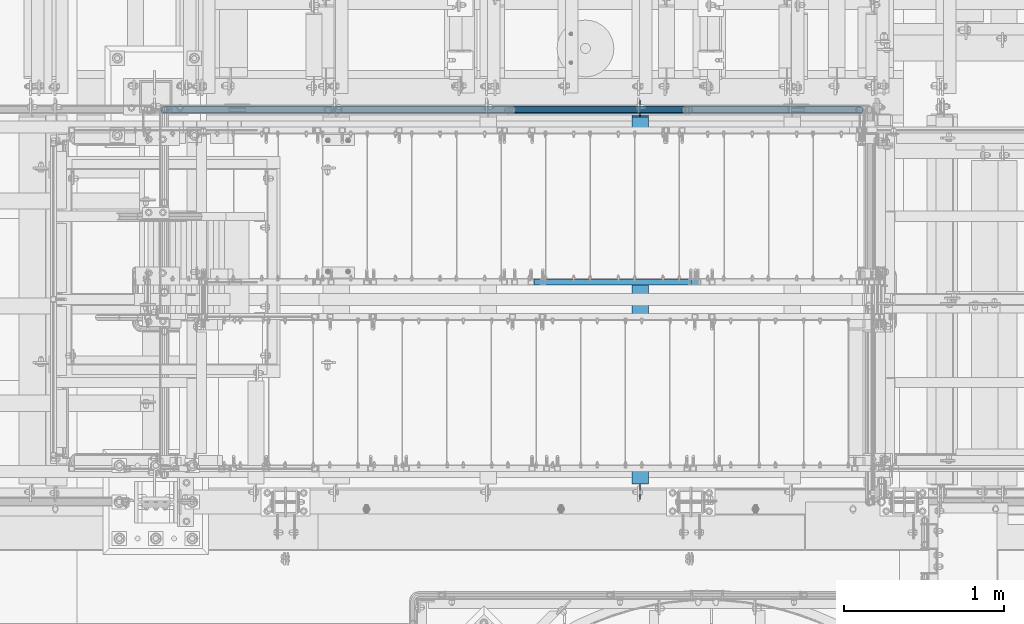
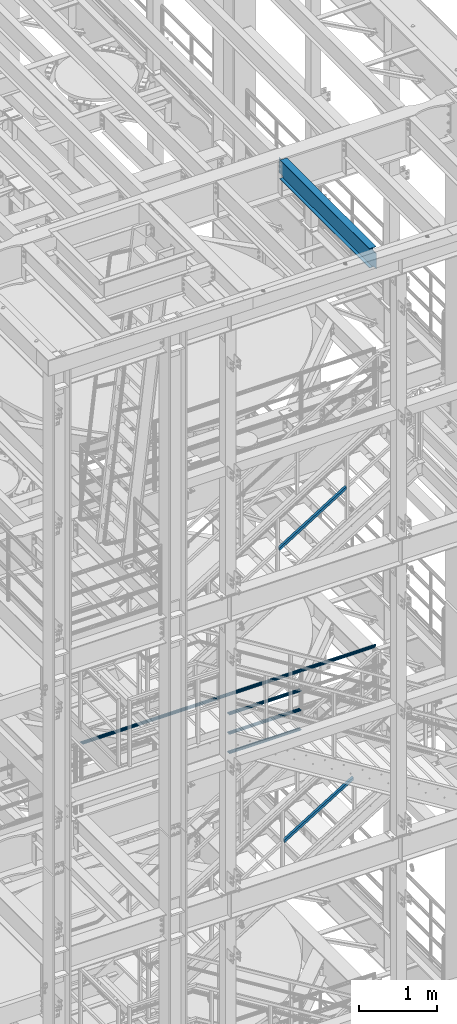
# One storey, part 976 of 1876: 5 beams, 2 members, 4 elements without a shape of their own.
"""IFC2X3 building model written with IfcOpenShell, lengths in millimetres."""

from ifc_helpers import new_model, si_unit, frame, origin_with_axes, place, context, subcontext, project, spatial, faceted_brep, material, type_object, element, aggregate, save


model = new_model("IFC2X3")

# Units and contexts
model_context = context("Model", 3, precision=1e-05, world=origin_with_axes())
body_context = subcontext(model_context, "Body", "Model", "MODEL_VIEW")
ifc_project = project(units=[si_unit("LENGTHUNIT", "METRE", prefix="MILLI"), si_unit("AREAUNIT", "SQUARE_METRE"), si_unit("VOLUMEUNIT", "CUBIC_METRE"), si_unit("MASSUNIT", "GRAM", prefix="KILO"), si_unit("TIMEUNIT", "SECOND"), si_unit("PLANEANGLEUNIT", "RADIAN"), si_unit("SOLIDANGLEUNIT", "STERADIAN"), si_unit("THERMODYNAMICTEMPERATUREUNIT", "DEGREE_CELSIUS"), si_unit("LUMINOUSINTENSITYUNIT", "LUMEN")], contexts=[model_context])

# Site, building, storey
site_placement = place(None, origin_with_axes())
site = spatial("IfcSite", under=ifc_project, at=site_placement, CompositionType="ELEMENT")
building_placement = place(site_placement, origin_with_axes())
building = spatial("IfcBuilding", under=site, at=building_placement, Name="Undefined", CompositionType="ELEMENT")
storey_placement = place(building_placement, origin_with_axes())
storey = spatial("IfcBuildingStorey", under=building, at=storey_placement, Name="Undefined", CompositionType="ELEMENT", Elevation=0.0)

# Assembly, beams
assembly_1_placement = place(storey_placement, origin_with_axes())
assembly_1 = element("IfcElementAssembly", 1, at=assembly_1_placement, inside=storey, Name="RAIL", AssemblyPlace="NOTDEFINED", PredefinedType="RIGID_FRAME")
ifc_material_1 = material()
beam_type_1 = type_object("IfcBeamType", Name="PIPE1-1/2SCH40", PredefinedType="NOTDEFINED")
beam_1_placement = place(assembly_1_placement, frame((5048.24999996466, -4654.55000114566, 13471.525), z_axis=(0.0, 0.0, 1.0), x_axis=(-1.0, 0.0, 0.0)))
beam_1 = element("IfcBeam", 2, at=beam_1_placement, type_object=beam_type_1, material=ifc_material_1, Name="RAIL", ObjectType="PIPE1-1/2SCH40", context=body_context, shape_type="Brep", body=[
    faceted_brep([(1068.12780699489, -12.0649999999996, 20.8971929933177), (1068.12780699489, -12.064999999986, 15.8661214311942), (1067.63437855703, -10.2235000000001, 17.7076214311801), (1064.89499998821, 0.0, 20.4470000000001), (1064.89499998821, 0.0, 24.1299999999992), (1067.63437855703, 10.2235000000001, 17.7076214311801), (1068.12780699489, 12.0650000000132, 15.8661214311669), (1068.12780699489, 12.0649999999996, 20.8971929933177), (1089.02499998822, 24.1300000000001, 0.0), (1076.95999998821, 20.8971929933186, 12.0650000000005), (1076.95999998821, 20.8971929933186, -12.0650000000005), (1073.77042842606, 17.7076214311801, 10.2235000000001), (1076.50980699488, 20.4470000000001, 0.0), (1073.77042842606, 17.7076214311801, -10.2235000000001), (1068.12780699489, 12.0650000000132, -15.8661214311669), (1068.12780699489, 12.0649999999996, -20.8971929933177), (1067.63437855703, 10.2235000000001, -17.7076214311801), (1064.89499998821, 0.0, -20.4470000000001), (1064.89499998821, 0.0, -24.1299999999992), (1068.12780699489, -12.064999999986, -15.8661214311942), (1068.12780699489, -12.0649999999996, -20.8971929933177), (1067.63437855703, -10.2235000000001, -17.7076214311801), (1089.02499998821, -24.1299999999865, 0.0), (1076.95999998821, -20.8971929933186, -12.0650000000005), (1076.95999998821, -20.8971929933186, 12.0650000000005), (1073.77042842609, -17.7076214311801, -10.2235000000001), (1076.50980699491, -20.4470000000001, 0.0), (1073.77042842609, -17.7076214311801, 10.2235000000001), (12.0650000000064, -20.8971929933177, -12.0649999999987), (20.8971929933249, -12.0650000000005, -20.8971929933177), (0.0, 24.1299999999992, 0.0), (12.0650000000064, 20.8971929933177, -12.0649999999987), (12.0650000000064, 20.8971929933177, 12.0649999999987), (20.8971929933249, 12.0650000000005, 20.8971929933177), (24.1300000000064, 0.0, 24.130000000001), (20.8971929933249, 12.0650000000005, -20.8971929933177), (24.1300000000063, 0.0, -24.130000000001), (24.1300000000063, 0.0, -20.4470000000001), (20.8971929933249, -12.0650000000005, -15.8661214311796), (21.3906214311868, -10.2235000000001, -17.7076214311819), (21.3906214311868, 10.2235000000001, -17.7076214311819), (20.8971929933249, 12.0650000000005, -15.8661214311796), (15.2545715621445, 17.7076214311801, -10.2235000000001), (12.5151929933249, 20.4470000000001, 0.0), (15.2545715621445, 17.7076214311801, 10.2235000000001), (20.8971929933249, 12.0650000000005, 15.8661214311796), (21.3906214311868, 10.2235000000001, 17.7076214311819), (24.1300000000064, 0.0, 20.4470000000001), (21.3906214311868, -10.2235000000001, 17.7076214311819), (20.8971929933249, -12.0650000000005, 15.8661214311796), (20.8971929933249, -12.0650000000005, 20.8971929933177), (12.0650000000064, -20.8971929933177, 12.0649999999987), (0.0, -24.1299999999992, 0.0), (15.2545715621445, -17.7076214311801, 10.2235000000001), (12.5151929933249, -20.4470000000001, 0.0), (15.2545715621445, -17.7076214311801, -10.2235000000001)], [[[0, 1, 2, 3, 4]], [[4, 3, 5, 6, 7]], [[8, 9, 10]], [[7, 6, 11, 12, 13, 14, 15, 10, 9]], [[16, 17, 18, 15, 14]], [[19, 20, 18, 17, 21]], [[22, 23, 24]], [[24, 23, 20, 19, 25, 26, 27, 1, 0]], [[28, 29, 20, 23]], [[30, 31, 32]], [[33, 34, 4, 7]], [[32, 33, 7, 9]], [[30, 32, 9, 8]], [[31, 30, 8, 10]], [[35, 31, 10, 15]], [[36, 35, 15, 18]], [[29, 36, 18, 20]], [[37, 36, 29, 38, 39]], [[40, 41, 35, 36, 37]], [[32, 31, 35, 41, 42, 43, 44, 45, 33]], [[33, 45, 46, 47, 34]], [[34, 47, 48, 49, 50]], [[34, 50, 0, 4]], [[50, 51, 24, 0]], [[51, 52, 22, 24]], [[52, 28, 23, 22]], [[51, 28, 52]], [[50, 49, 53, 54, 55, 38, 29, 28, 51]], [[55, 54, 26, 25]], [[21, 39, 38, 55, 25, 19]], [[37, 39, 21, 17]], [[40, 37, 17, 16]], [[42, 41, 40, 16, 14, 13]], [[43, 42, 13, 12]], [[44, 43, 12, 11]], [[5, 46, 45, 44, 11, 6]], [[47, 46, 5, 3]], [[48, 47, 3, 2]], [[53, 49, 48, 2, 1, 27]], [[54, 53, 27, 26]]]),
])
beam_2_placement = place(assembly_1_placement, frame((3959.22499997644, -4654.55000114568, 13776.325), z_axis=(0.0, 0.0, -1.0), x_axis=(1.0, 0.0, 0.0)))
beam_2 = element("IfcBeam", 3, at=beam_2_placement, type_object=beam_type_1, material=ifc_material_1, Name="RAIL", ObjectType="PIPE1-1/2SCH40", context=body_context, shape_type="Brep", body=[
    faceted_brep([(0.0, 24.1299999999992, 0.0), (12.0650000000064, 20.8971929933177, -12.0649999999987), (12.0650000000064, 20.8971929933177, 12.0649999999987), (12.0650000000064, -20.8971929933177, 12.0649999999987), (12.0650000000064, -20.8971929933177, -12.0649999999987), (0.0, -24.1299999999992, 0.0), (20.8971929933249, -12.0650000000005, 20.8971929933177), (20.8971929933249, -12.0650000000005, 15.8661214311796), (15.2545715621445, -17.7076214311801, 10.2235000000001), (12.5151929933249, -20.4470000000001, 0.0), (15.2545715621445, -17.7076214311801, -10.2235000000001), (20.8971929933249, -12.0650000000005, -15.8661214311796), (20.8971929933249, -12.0650000000005, -20.8971929933177), (24.1300000000063, 0.0, -20.4470000000001), (24.1300000000063, 0.0, -24.130000000001), (21.3906214311868, -10.2235000000001, -17.7076214311819), (21.3906214311868, 10.2235000000001, -17.7076214311819), (20.8971929933249, 12.0650000000005, -15.8661214311796), (20.8971929933249, 12.0650000000005, -20.8971929933177), (15.2545715621445, 17.7076214311801, -10.2235000000001), (12.5151929933249, 20.4470000000001, 0.0), (15.2545715621445, 17.7076214311801, 10.2235000000001), (20.8971929933249, 12.0650000000005, 15.8661214311796), (20.8971929933249, 12.0650000000005, 20.8971929933177), (21.3906214311868, 10.2235000000001, 17.7076214311819), (24.1300000000064, 0.0, 20.4470000000001), (24.1300000000064, 0.0, 24.130000000001), (21.3906214311868, -10.2235000000001, 17.7076214311819), (1089.02499998822, 24.1300000000001, 0.0), (1076.95999998821, 20.8971929933186, -12.0650000000005), (1068.12780699489, 12.0649999999996, -20.8971929933177), (1089.02499998821, -24.1299999999865, 0.0), (1076.95999998821, -20.8971929933186, -12.0650000000005), (1076.95999998821, -20.8971929933186, 12.0650000000005), (1068.12780699489, -12.0649999999996, 20.8971929933177), (1068.12780699489, -12.0649999999996, -20.8971929933177), (1064.89499998821, 0.0, -24.1299999999992), (1067.63437855703, 10.2235000000001, -17.7076214311801), (1064.89499998821, 0.0, -20.4470000000001), (1068.12780699489, 12.0650000000132, -15.8661214311669), (1068.12780699489, -12.064999999986, -15.8661214311942), (1067.63437855703, -10.2235000000001, -17.7076214311801), (1073.77042842609, -17.7076214311801, -10.2235000000001), (1076.50980699491, -20.4470000000001, 0.0), (1073.77042842609, -17.7076214311801, 10.2235000000001), (1068.12780699489, -12.064999999986, 15.8661214311942), (1067.63437855703, -10.2235000000001, 17.7076214311801), (1064.89499998821, 0.0, 20.4470000000001), (1064.89499998821, 0.0, 24.1299999999992), (1068.12780699489, 12.0649999999996, 20.8971929933177), (1076.95999998821, 20.8971929933186, 12.0650000000005), (1068.12780699489, 12.0650000000132, 15.8661214311669), (1073.77042842606, 17.7076214311801, 10.2235000000001), (1076.50980699488, 20.4470000000001, 0.0), (1073.77042842606, 17.7076214311801, -10.2235000000001), (1067.63437855703, 10.2235000000001, 17.7076214311801)], [[[0, 1, 2]], [[3, 4, 5]], [[6, 7, 8, 9, 10, 11, 12, 4, 3]], [[13, 14, 12, 11, 15]], [[16, 17, 18, 14, 13]], [[2, 1, 18, 17, 19, 20, 21, 22, 23]], [[23, 22, 24, 25, 26]], [[26, 25, 27, 7, 6]], [[1, 0, 28, 29]], [[18, 1, 29, 30]], [[31, 32, 33]], [[6, 3, 33, 34]], [[3, 5, 31, 33]], [[5, 4, 32, 31]], [[4, 12, 35, 32]], [[12, 14, 36, 35]], [[14, 18, 30, 36]], [[37, 38, 36, 30, 39]], [[40, 35, 36, 38, 41]], [[33, 32, 35, 40, 42, 43, 44, 45, 34]], [[34, 45, 46, 47, 48]], [[26, 6, 34, 48]], [[2, 23, 49, 50]], [[23, 26, 48, 49]], [[0, 2, 50, 28]], [[28, 50, 29]], [[49, 51, 52, 53, 54, 39, 30, 29, 50]], [[48, 47, 55, 51, 49]], [[25, 24, 55, 47]], [[55, 24, 22, 21, 52, 51]], [[21, 20, 53, 52]], [[20, 19, 54, 53]], [[19, 17, 16, 37, 39, 54]], [[16, 13, 38, 37]], [[13, 15, 41, 38]], [[41, 15, 11, 10, 42, 40]], [[10, 9, 43, 42]], [[9, 8, 44, 43]], [[8, 7, 27, 46, 45, 44]], [[27, 25, 47, 46]]]),
])
beam_3_placement = place(assembly_1_placement, frame((3959.22499997644, -4654.55000114568, 14081.125), z_axis=(0.0, 0.0, -1.0), x_axis=(1.0, 0.0, 0.0)))
beam_3 = element("IfcBeam", 4, at=beam_3_placement, type_object=beam_type_1, material=ifc_material_1, Name="RAIL", ObjectType="PIPE1-1/2SCH40", context=body_context, shape_type="Brep", body=[
    faceted_brep([(0.0, 24.1299999999992, 0.0), (12.0650000000064, 20.8971929933177, -12.0649999999987), (12.0650000000064, 20.8971929933177, 12.0649999999987), (12.0650000000064, -20.8971929933177, 12.0649999999987), (12.0650000000064, -20.8971929933177, -12.0649999999987), (0.0, -24.1299999999992, 0.0), (20.8971929933249, -12.0650000000005, 20.8971929933177), (20.8971929933249, -12.0650000000005, 15.8661214311796), (15.2545715621445, -17.7076214311801, 10.2235000000001), (12.5151929933249, -20.4470000000001, 0.0), (15.2545715621445, -17.7076214311801, -10.2235000000001), (20.8971929933249, -12.0650000000005, -15.8661214311796), (20.8971929933249, -12.0650000000005, -20.8971929933177), (24.1300000000063, 0.0, -20.4470000000001), (24.1300000000063, 0.0, -24.130000000001), (21.3906214311868, -10.2235000000001, -17.7076214311819), (21.3906214311868, 10.2235000000001, -17.7076214311819), (20.8971929933249, 12.0650000000005, -15.8661214311796), (20.8971929933249, 12.0650000000005, -20.8971929933177), (15.2545715621445, 17.7076214311801, -10.2235000000001), (12.5151929933249, 20.4470000000001, 0.0), (15.2545715621445, 17.7076214311801, 10.2235000000001), (20.8971929933249, 12.0650000000005, 15.8661214311796), (20.8971929933249, 12.0650000000005, 20.8971929933177), (21.3906214311868, 10.2235000000001, 17.7076214311819), (24.1300000000064, 0.0, 20.4470000000001), (24.1300000000064, 0.0, 24.130000000001), (21.3906214311868, -10.2235000000001, 17.7076214311819), (1089.02499998822, 24.1300000000001, 0.0), (1076.95999998821, 20.8971929933186, -12.0650000000005), (1068.12780699489, 12.0649999999996, -20.8971929933177), (1089.02499998821, -24.1299999999865, 0.0), (1076.95999998821, -20.8971929933186, -12.0650000000005), (1076.95999998821, -20.8971929933186, 12.0650000000005), (1068.12780699489, -12.0649999999996, 20.8971929933177), (1068.12780699489, -12.0649999999996, -20.8971929933177), (1064.89499998821, 0.0, -24.1299999999992), (1067.63437855703, 10.2235000000001, -17.7076214311801), (1064.89499998821, 0.0, -20.4470000000001), (1068.12780699489, 12.0650000000132, -15.8661214311669), (1068.12780699489, -12.064999999986, -15.8661214311942), (1067.63437855703, -10.2235000000001, -17.7076214311801), (1073.77042842609, -17.7076214311801, -10.2235000000001), (1076.50980699491, -20.4470000000001, 0.0), (1073.77042842609, -17.7076214311801, 10.2235000000001), (1068.12780699489, -12.064999999986, 15.8661214311942), (1067.63437855703, -10.2235000000001, 17.7076214311801), (1064.89499998821, 0.0, 20.4470000000001), (1064.89499998821, 0.0, 24.1299999999992), (1068.12780699489, 12.0649999999996, 20.8971929933177), (1076.95999998821, 20.8971929933186, 12.0650000000005), (1068.12780699489, 12.0650000000132, 15.8661214311669), (1073.77042842606, 17.7076214311801, 10.2235000000001), (1076.50980699488, 20.4470000000001, 0.0), (1073.77042842606, 17.7076214311801, -10.2235000000001), (1067.63437855703, 10.2235000000001, 17.7076214311801)], [[[0, 1, 2]], [[3, 4, 5]], [[6, 7, 8, 9, 10, 11, 12, 4, 3]], [[13, 14, 12, 11, 15]], [[16, 17, 18, 14, 13]], [[2, 1, 18, 17, 19, 20, 21, 22, 23]], [[23, 22, 24, 25, 26]], [[26, 25, 27, 7, 6]], [[1, 0, 28, 29]], [[18, 1, 29, 30]], [[31, 32, 33]], [[6, 3, 33, 34]], [[3, 5, 31, 33]], [[5, 4, 32, 31]], [[4, 12, 35, 32]], [[12, 14, 36, 35]], [[14, 18, 30, 36]], [[37, 38, 36, 30, 39]], [[40, 35, 36, 38, 41]], [[33, 32, 35, 40, 42, 43, 44, 45, 34]], [[34, 45, 46, 47, 48]], [[26, 6, 34, 48]], [[2, 23, 49, 50]], [[23, 26, 48, 49]], [[0, 2, 50, 28]], [[28, 50, 29]], [[49, 51, 52, 53, 54, 39, 30, 29, 50]], [[48, 47, 55, 51, 49]], [[25, 24, 55, 47]], [[55, 24, 22, 21, 52, 51]], [[21, 20, 53, 52]], [[20, 19, 54, 53]], [[19, 17, 16, 37, 39, 54]], [[16, 13, 38, 37]], [[13, 15, 41, 38]], [[41, 15, 11, 10, 42, 40]], [[10, 9, 43, 42]], [[9, 8, 44, 43]], [[8, 7, 27, 46, 45, 44]], [[27, 25, 47, 46]]]),
])
beam_4_placement = place(assembly_1_placement, frame((1757.04499999999, -4654.55000114569, 14385.925), z_axis=(0.0, 0.0, -1.0), x_axis=(1.0, 0.0, 0.0)))
beam_4 = element("IfcBeam", 5, at=beam_4_placement, type_object=beam_type_1, material=ifc_material_1, Name="RAIL", ObjectType="PIPE1-1/2SCH40", context=body_context, shape_type="Brep", body=[
    faceted_brep([(24.1300000000001, -20.4469999999999, 0.0), (34.3535000000002, -17.7076214311803, 10.2235000000001), (4370.00649995292, -17.7076214311801, 10.2235000000001), (4380.22999995292, -20.4470000000001, 0.0), (41.8376214311802, -10.2235000000001, 17.7076214311819), (4362.52237852174, -10.2235000000001, 17.7076214311801), (44.5770000000002, 0.0, 20.4470000000001), (4359.78299995292, 0.0, 20.4470000000001), (41.8376214311802, 10.2235000000001, 17.7076214311819), (4362.52237852174, 10.2235000000001, 17.7076214311801), (34.3535000000002, 17.7076214311803, 10.2235000000001), (4370.00649995292, 17.7076214311801, 10.2235000000001), (24.1300000000001, 20.4469999999999, 0.0), (4380.22999995292, 20.4470000000001, 0.0), (13.9065000000001, 17.7076214311803, -10.2235000000001), (4390.45349995292, 17.7076214311801, -10.2235000000001), (6.42237856882002, 10.2235000000001, -17.7076214311819), (4397.9376213841, 10.2235000000001, -17.7076214311801), (3.68299999999999, 0.0, -20.4470000000001), (4400.67699995292, 0.0, -20.4470000000001), (6.42237856882002, -10.2235000000001, -17.7076214311819), (4397.9376213841, -10.2235000000001, -17.7076214311801), (13.9065000000001, -17.7076214311803, -10.2235000000001), (4390.45349995292, -17.7076214311801, -10.2235000000001), (24.1299999999854, -24.1299999999992, 0.0), (12.0650000000064, -20.8971929933177, -12.0649999999987), (4392.29499995292, -20.8971929933186, -12.0650000000005), (4380.22999995292, -24.1300000000001, 0.0), (3.23280700668147, -12.0650000000001, -20.8971929933177), (4401.12719294624, -12.0649999999996, -20.8971929933177), (-1.45519152283669e-11, 0.0, -24.130000000001), (4404.35999995292, 0.0, -24.1299999999992), (3.23280700668147, 12.0650000000001, -20.8971929933177), (4401.12719294624, 12.0649999999996, -20.8971929933177), (12.0650000000064, 20.8971929933177, -12.0649999999987), (4392.29499995292, 20.8971929933186, -12.0650000000005), (24.1300000000047, 24.1299999999992, 0.0), (4380.22999995292, 24.1300000000001, 0.0), (36.1949999999997, 20.8971929933184, 12.0649999999987), (4368.16499995292, 20.8971929933186, 12.0650000000005), (45.0271929933187, 12.0650000000001, 20.8971929933177), (4359.3328069596, 12.0649999999996, 20.8971929933177), (48.2600000000002, 0.0, 24.130000000001), (4356.09999995292, 0.0, 24.1299999999992), (45.0271929933187, -12.0650000000001, 20.8971929933177), (4359.3328069596, -12.0649999999996, 20.8971929933177), (36.1949999999997, -20.8971929933184, 12.0649999999987), (4368.16499995292, -20.8971929933186, 12.0650000000005)], [[[0, 1, 2, 3]], [[1, 4, 5, 2]], [[4, 6, 7, 5]], [[6, 8, 9, 7]], [[8, 10, 11, 9]], [[10, 12, 13, 11]], [[12, 14, 15, 13]], [[14, 16, 17, 15]], [[16, 18, 19, 17]], [[18, 20, 21, 19]], [[20, 22, 23, 21]], [[22, 0, 3, 23]], [[24, 25, 26, 27]], [[25, 28, 29, 26]], [[28, 30, 31, 29]], [[30, 32, 33, 31]], [[32, 34, 35, 33]], [[34, 36, 37, 35]], [[36, 38, 39, 37]], [[38, 40, 41, 39]], [[40, 42, 43, 41]], [[42, 44, 45, 43]], [[44, 46, 47, 45]], [[46, 24, 27, 47]], [[29, 31, 33, 35, 37, 39, 41, 43, 45, 47, 27, 26], [5, 7, 9, 11, 13, 15, 17, 19, 21, 23, 3, 2]], [[46, 44, 42, 40, 38, 36, 34, 32, 30, 28, 25, 24], [22, 20, 18, 16, 14, 12, 10, 8, 6, 4, 1, 0]]]),
])
aggregate(assembly_1, [beam_1, beam_2, beam_3, beam_4])

# Assembly, beam
assembly_2_placement = place(storey_placement, origin_with_axes())
assembly_2 = element("IfcElementAssembly", 6, at=assembly_2_placement, inside=storey, Name="BEAM", AssemblyPlace="NOTDEFINED", PredefinedType="RIGID_FRAME")
ifc_material_2 = material(Name="STEEL/A992")
beam_type_2 = type_object("IfcBeamType", Name="W12X16", PredefinedType="NOTDEFINED")
beam_5_placement = place(assembly_2_placement, frame((4762.5, -7112.0, 22402.8), z_axis=(0.0, 0.0, 1.0), x_axis=(0.0, 1.0, 0.0)))
beam_5 = element("IfcBeam", 7, at=beam_5_placement, type_object=beam_type_2, material=ifc_material_2, Name="BEAM", ObjectType="W12X16", context=body_context, shape_type="Brep", body=[
    faceted_brep([(17.4625000000005, -3.17500000000018, -126.999999999999), (17.4625000000005, 3.17500000000018, -126.999999999999), (100.012500190734, 3.17500000000018, -126.999999999999), (100.012500190734, -3.17500000000018, -126.999999999999), (104.87257970878, 3.17500000000018, -127.966729922587), (104.87257970878, -3.17500000000018, -127.966729922587), (108.992756176934, 3.17500000000018, -130.719743823065), (108.992756176934, -3.17500000000018, -130.719743823065), (111.745770077412, 3.17500000000018, -134.839920291219), (111.745770077412, -3.17500000000018, -134.839920291219), (112.7125, -3.17500000000018, -139.699999809264), (112.7125, 3.17500000000018, -139.699999809264), (112.712500000001, 3.17500000000018, -146.049999999999), (112.7125, 50.8000000000002, -146.05), (112.7125, 50.8000000000002, -152.4), (112.7125, -50.8000000000002, -152.4), (112.7125, -50.8000000000002, -146.05), (112.712500000001, -3.17500000000018, -146.049999999999), (2412.20625, 50.8000000000002, 146.049999999999), (2412.20625, 3.17500000000018, 146.049999999999), (112.712500000001, 3.17500000000018, 146.05), (112.712500000001, 50.8000000000002, 146.049999999999), (100.012500190735, -3.17500000000018, 114.299999999996), (100.012500190735, 3.17500000000018, 114.299999999996), (17.4624999999996, 3.17500000000018, 114.299999999996), (17.4624999999996, -3.17500000000018, 114.299999999996), (104.872579708781, -3.17500000000018, 115.266729922583), (104.872579708781, 3.17500000000018, 115.266729922583), (108.992756176935, -3.17500000000018, 118.019743823061), (108.992756176935, 3.17500000000018, 118.019743823061), (111.745770077413, -3.17500000000018, 122.139920291214), (111.745770077413, 3.17500000000018, 122.139920291214), (112.712500000001, -3.17500000000018, 126.999999809261), (112.712500000001, 3.17500000000018, 126.999999809261), (2412.20625, -50.8000000000002, 152.400000000001), (2412.20625, 50.8000000000002, 152.400000000001), (112.712500000001, 50.8000000000002, 152.400000000001), (112.712500000001, -50.8000000000002, 152.400000000001), (2412.20625, -50.8000000000002, 146.049999999999), (112.712500000001, -50.8000000000002, 146.049999999999), (2412.20625, -3.17500000000018, 146.049999999999), (112.712500000001, -3.17500000000018, 146.05), (2412.20625, -3.17500000000018, 126.999999809268), (2412.20625, 3.17500000000018, 126.999999809268), (2413.17297992259, -3.17500000000018, 122.139920291222), (2413.17297992259, 3.17500000000018, 122.139920291222), (2415.92599382307, -3.17500000000018, 118.019743823068), (2415.92599382307, 3.17500000000018, 118.019743823068), (2420.04617029122, -3.17500000000018, 115.26672992259), (2420.04617029122, 3.17500000000018, 115.26672992259), (2424.90624980927, -3.17500000000018, 114.300000000003), (2424.90624980927, 3.17500000000018, 114.300000000003), (2520.15625, -3.17500000000018, 114.300000000003), (2520.15625, 3.17500000000018, 114.300000000003), (2520.15625, -3.17500000000018, -126.999999999996), (2520.15625, 3.17500000000018, -126.999999999996), (2437.60624980927, -3.17500000000018, -126.999999999996), (2437.60624980927, 3.17500000000018, -126.999999999996), (2432.74617029122, -3.17500000000018, -127.966729922584), (2432.74617029122, 3.17500000000018, -127.966729922584), (2428.62599382307, -3.17500000000018, -130.719743823061), (2428.62599382307, 3.17500000000018, -130.719743823061), (2425.87297992259, -3.17500000000018, -134.839920291215), (2425.87297992259, 3.17500000000018, -134.839920291215), (2424.90625, -3.17500000000018, -139.699999809261), (2424.90625, 3.17500000000018, -139.699999809261), (2424.90625, -3.17500000000018, -146.049999999999), (2424.90625, -50.8000000000002, -146.049999999999), (2424.90625, -50.8000000000002, -152.400000000001), (2424.90625, 50.8000000000002, -152.400000000001), (2424.90625, 50.8000000000002, -146.049999999999), (2424.90625, 3.17500000000018, -146.049999999999)], [[[0, 1, 2, 3]], [[3, 2, 4, 5]], [[5, 4, 6, 7]], [[7, 6, 8, 9]], [[10, 11, 12, 13, 14, 15, 16, 17]], [[9, 8, 11, 10]], [[18, 19, 20, 21]], [[22, 23, 24, 25]], [[26, 27, 23, 22]], [[28, 29, 27, 26]], [[30, 31, 29, 28]], [[32, 33, 31, 30]], [[34, 35, 36, 37]], [[38, 34, 37, 39]], [[40, 38, 39, 41]], [[37, 36, 21, 20, 33, 32, 41, 39]], [[35, 18, 21, 36]], [[34, 38, 40, 42, 43, 19, 18, 35]], [[44, 45, 43, 42]], [[46, 47, 45, 44]], [[48, 49, 47, 46]], [[50, 51, 49, 48]], [[52, 53, 51, 50]], [[53, 52, 54, 55]], [[54, 56, 57, 55]], [[58, 59, 57, 56]], [[60, 61, 59, 58]], [[62, 63, 61, 60]], [[64, 65, 63, 62]], [[66, 67, 68, 69, 70, 71, 65, 64]], [[67, 66, 17, 16]], [[68, 67, 16, 15]], [[69, 68, 15, 14]], [[70, 69, 14, 13]], [[71, 70, 13, 12]], [[6, 4, 2, 1, 24, 23, 27, 29, 31, 33, 20, 19, 43, 45, 47, 49, 51, 53, 55, 57, 59, 61, 63, 65, 71, 12, 11, 8]], [[25, 24, 1, 0]], [[66, 64, 62, 60, 58, 56, 54, 52, 50, 48, 46, 44, 42, 40, 41, 32, 30, 28, 26, 22, 25, 0, 3, 5, 7, 9, 10, 17]]]),
])
aggregate(assembly_2, [beam_5])

# Assembly, member
assembly_3_placement = place(storey_placement, origin_with_axes())
assembly_3 = element("IfcElementAssembly", 8, at=assembly_3_placement, inside=storey, Name="RAIL", AssemblyPlace="NOTDEFINED", PredefinedType="RIGID_FRAME")
ifc_material_3 = material()
member_type = type_object("IfcMemberType", Name="HSS1-1/2X1-1/2X1/8", PredefinedType="NOTDEFINED")
member_1_placement = place(assembly_3_placement, frame((4152.90000017869, -5734.05000114554, 12657.2240906313), z_axis=(-0.523953411146183, 0.0, 0.851746924237639), x_axis=(0.851746924237639, 0.0, 0.523953411146184)))
member_1 = element("IfcMember", 9, at=member_1_placement, type_object=member_type, material=ifc_material_3, Name="RAIL", ObjectType="HSS1-1/2X1-1/2X1/8", context=body_context, shape_type="Brep", body=[
    faceted_brep([(10.6471616099025, -19.0499992349996, -19.0499992350033), (34.0844334038557, -19.0499992349996, 19.0499992349978), (34.0844334038557, 19.0499992349996, 19.0499992349978), (10.6471616099025, 19.0499992349996, -19.0499992350033), (32.1313273721225, 15.8749992829999, 15.874999282998), (32.1313273721225, -15.8749992829999, 15.874999282998), (12.6002676416374, -15.8749992829999, -15.8749992830035), (12.6002676416374, 15.8749992829999, -15.8749992830035), (1210.94501017189, 19.0499992349996, -19.0499992339264), (1210.94501017189, -19.0499992349996, -19.0499992339264), (1234.38228196586, -19.0499992349996, 19.0499992361129), (1234.38228196586, 19.0499992349996, 19.0499992361129), (1232.42917593412, -15.8749992829999, 15.8749992841094), (1232.42917593412, 15.8749992829999, 15.8749992841094), (1212.89811620362, 15.8749992829999, -15.874999281923), (1212.89811620362, -15.8749992829999, -15.874999281923)], [[[0, 1, 2, 3], [4, 5, 6, 7]], [[0, 3, 8, 9]], [[1, 0, 9, 10]], [[2, 1, 10, 11]], [[3, 2, 11, 8]], [[10, 9, 8, 11], [12, 13, 14, 15]], [[5, 4, 13, 12]], [[4, 7, 14, 13]], [[7, 6, 15, 14]], [[6, 5, 12, 15]]]),
])
aggregate(assembly_3, [member_1])

assembly_4_placement = place(storey_placement, origin_with_axes())
assembly_4 = element("IfcElementAssembly", 10, at=assembly_4_placement, inside=storey, Name="RAIL", AssemblyPlace="NOTDEFINED", PredefinedType="RIGID_FRAME")
member_2_placement = place(assembly_4_placement, frame((4078.28749856853, -5734.05000114554, 17276.1695094359), z_axis=(-0.526627379729772, 0.0, 0.850096231563789), x_axis=(0.850096231563789, 0.0, 0.526627379729772)))
member_2 = element("IfcMember", 11, at=member_2_placement, type_object=member_type, material=ifc_material_3, Name="RAIL", ObjectType="HSS1-1/2X1-1/2X1/8", context=body_context, shape_type="Brep", body=[
    faceted_brep([(10.6079144021951, -19.0499992349996, -19.0499992349669), (34.210539160511, -19.0499992349996, 19.0499992350342), (34.210539160511, 19.0499992349996, 19.0499992350342), (10.6079144021951, 19.0499992349996, -19.0499992349669), (32.243653714735, 15.8749992829999, 15.8749992830344), (32.243653714735, -15.8749992829999, 15.8749992830344), (12.574799847971, -15.8749992829999, -15.8749992829671), (12.574799847971, 15.8749992829999, -15.8749992829671), (1176.8214724105, 19.0499992349996, -19.0499992332807), (1176.8214724105, -19.0499992349996, -19.0499992332807), (1200.42409716882, -19.0499992349996, 19.0499992367259), (1200.42409716882, 19.0499992349996, 19.0499992367259), (1198.45721172304, -15.8749992829999, 15.8749992847224), (1198.45721172304, 15.8749992829999, 15.8749992847224), (1178.78835785628, 15.8749992829999, -15.8749992812809), (1178.78835785628, -15.8749992829999, -15.8749992812809)], [[[0, 1, 2, 3], [4, 5, 6, 7]], [[8, 9, 0, 3]], [[9, 10, 1, 0]], [[10, 11, 2, 1]], [[11, 8, 3, 2]], [[10, 9, 8, 11], [12, 13, 14, 15]], [[13, 12, 5, 4]], [[14, 13, 4, 7]], [[15, 14, 7, 6]], [[12, 15, 6, 5]]]),
])
aggregate(assembly_4, [member_2])

save(model, "model.ifc")
